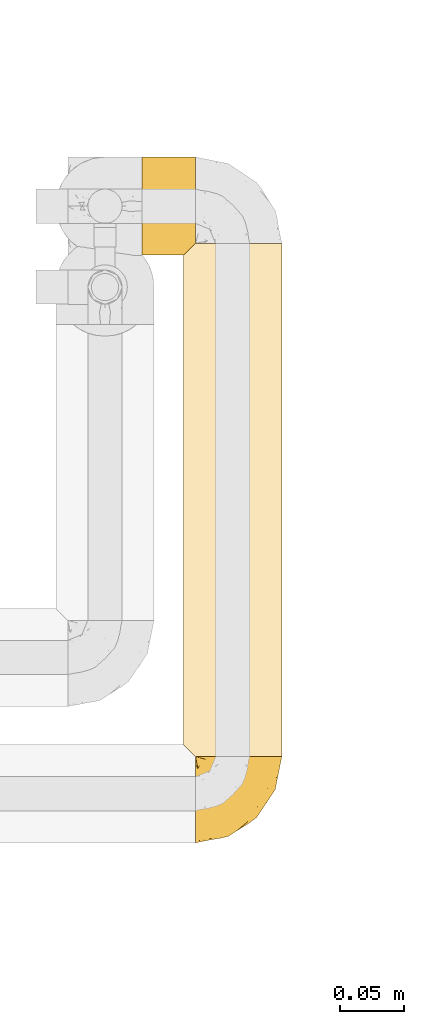
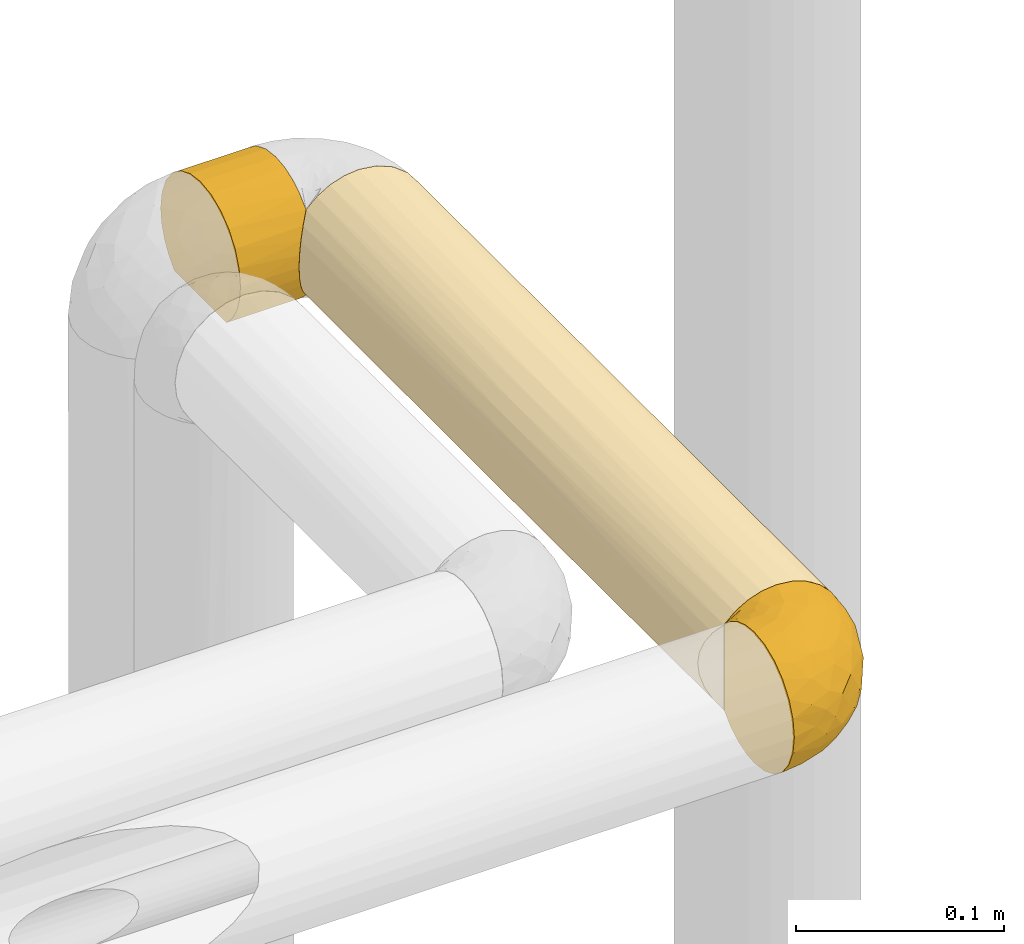
# One storey, part 84 of 827: 3 coverings.
"""IFC2X3 building model written with IfcOpenShell, lengths in millimetres."""

import ifcopenshell
import ifcopenshell.guid

model = None  # the IFC model being written
_history = None  # IfcOwnerHistory: only IFC2X3 demands one
_inside = {}  # id of a spatial element -> (the spatial element, [elements in it])
_under = {}  # id of a project, library or spatial element -> (it, [spatial elements below it])
_declared = {}  # id of a project -> (the project, [libraries it declares])
_typed = {}  # id of a type object -> (the type object, [elements of that type])
_made_of = {}  # id of a material, layer set ... -> (it, [elements and type objects made of it])


def new_model(schema):
    """Start an empty IFC model of exactly this schema.

    Asked for "IFC4X3", IfcOpenShell would pick the latest addendum, in which some entities
    have other attributes; the version numbers below select the first issue.
    IFC2X3 requires an IfcOwnerHistory on every rooted entity: one is made here for all.
    """
    global model, _history
    if schema == "IFC4X3":
        model = ifcopenshell.file(schema_version=(4, 3, 0, 0))
    else:
        model = ifcopenshell.file(schema=schema)
    _inside.clear()
    _under.clear()
    _declared.clear()
    _typed.clear()
    _made_of.clear()
    _history = None
    if model.schema == "IFC2X3":
        org = make("IfcOrganization", Name="unknown")
        user = make(
            "IfcPersonAndOrganization",
            ThePerson=make("IfcPerson", FamilyName="unknown"),
            TheOrganization=org,
        )
        app = make(
            "IfcApplication",
            ApplicationDeveloper=org,
            Version="unknown",
            ApplicationFullName="unknown",
            ApplicationIdentifier="unknown",
        )
        _history = make(
            "IfcOwnerHistory",
            OwningUser=user,
            OwningApplication=app,
            ChangeAction="ADDED",
            CreationDate=0,
        )
    return model


def make(cls, **values):
    """One entity of the class cls with the attributes given. An attribute that is None is left unset."""
    return model.create_entity(
        cls, **{name: value for name, value in values.items() if value is not None}
    )


def entity(cls, *values):
    """Any entity or typed value of the class cls, its attributes in the order of the schema. None: left unset."""
    e = model.create_entity(cls)
    for i, value in enumerate(values):
        if value is not None:
            e[i] = value
    return e


def rooted(cls, **values):
    """An entity with a GlobalId (a new one), such as an element, a storey or a relation."""
    return make(cls, GlobalId=ifcopenshell.guid.new(), OwnerHistory=_history, **values)


def si_unit(unit_type, name, prefix=None):
    """IfcSIUnit, for example si_unit("LENGTHUNIT", "METRE", prefix="MILLI")."""
    return make("IfcSIUnit", UnitType=unit_type, Prefix=prefix, Name=name)


def converted_unit(unit_type, name, factor, base, dimensions=None, offset=None):
    """IfcConversionBasedUnit, such as the inch: factor (a typed value) times the base unit."""
    return make(
        "IfcConversionBasedUnit"
        if offset is None
        else "IfcConversionBasedUnitWithOffset",
        ConversionOffset=offset,
        Dimensions=None
        if dimensions is None
        else entity("IfcDimensionalExponents", *dimensions),
        UnitType=unit_type,
        Name=name,
        ConversionFactor=make(
            "IfcMeasureWithUnit", ValueComponent=factor, UnitComponent=base
        ),
    )


def derived_unit(unit_type, elements):
    """IfcDerivedUnit: a product of units, each with its exponent."""
    return make(
        "IfcDerivedUnit",
        Elements=[
            make("IfcDerivedUnitElement", Unit=unit, Exponent=power)
            for unit, power in elements
        ],
        UnitType=unit_type,
    )


def assignment(units):
    """IfcUnitAssignment: the units of a project."""
    return None if units is None else make("IfcUnitAssignment", Units=units)


def point(xyz):
    """IfcCartesianPoint."""
    return None if xyz is None else make("IfcCartesianPoint", Coordinates=xyz)


def direction(xyz):
    """IfcDirection."""
    return None if xyz is None else make("IfcDirection", DirectionRatios=xyz)


def frame(location, z_axis=None, x_axis=None):
    """IfcAxis2Placement3D, a coordinate frame: its origin and axes. An axis left out is left unset."""
    return make(
        "IfcAxis2Placement3D",
        Location=point(location),
        Axis=direction(z_axis),
        RefDirection=direction(x_axis),
    )


def origin():
    """The frame at (0, 0, 0) with its axes left unset."""
    return frame((0.0, 0.0, 0.0))


def place(relative_to, where):
    """IfcLocalPlacement: puts the frame where relative to a parent placement (None: the world)."""
    return make(
        "IfcLocalPlacement", PlacementRelTo=relative_to, RelativePlacement=where
    )


def context(
    kind, dimensions, precision=None, world=None, true_north=None, identifier=None
):
    """IfcGeometricRepresentationContext, for example the 3D "Model" context."""
    return make(
        "IfcGeometricRepresentationContext",
        ContextIdentifier=identifier,
        ContextType=kind,
        CoordinateSpaceDimension=dimensions,
        Precision=precision,
        WorldCoordinateSystem=world,
        TrueNorth=true_north,
    )


def subcontext(parent, identifier, kind, view, scale=None):
    """IfcGeometricRepresentationSubContext, for example "Body" below "Model"."""
    return make(
        "IfcGeometricRepresentationSubContext",
        ContextIdentifier=identifier,
        ContextType=kind,
        ParentContext=parent,
        TargetScale=scale,
        TargetView=view,
    )


def project(units=None, contexts=None):
    """IfcProject with its units and contexts."""
    return rooted(
        "IfcProject",
        Name="project",
        RepresentationContexts=contexts,
        UnitsInContext=assignment(units),
    )


def spatial(cls, under=None, at=None, **own):
    """A site, building, storey or space (cls), placed at a placement, below another one or the project."""
    s = rooted(cls, ObjectPlacement=at, **own)
    if under is not None:
        _under.setdefault(under.id(), (under, []))[1].append(s)
    return s


def faces_of(points, faces, orient=None, outer=None):
    """IfcFace entities. A face is a list of loops; a loop is a list of indices into points, from 0.

    orient and outer hold one flag for each loop. By default every Orientation is true, the
    first loop of a face is its IfcFaceOuterBound and the others are IfcFaceBound.
    """
    made = []
    for i, loops in enumerate(faces):
        bounds = []
        for j, loop in enumerate(loops):
            is_outer = j == 0 if outer is None else outer[i][j]
            bounds.append(
                make(
                    "IfcFaceOuterBound" if is_outer else "IfcFaceBound",
                    Bound=make("IfcPolyLoop", Polygon=[points[k] for k in loop]),
                    Orientation=True if orient is None else orient[i][j],
                )
            )
        made.append(make("IfcFace", Bounds=bounds))
    return made


def faceted_brep(points, faces, orient=None, outer=None, voids=None):
    """IfcFacetedBrep: a solid bounded by flat faces; with voids (closed shells), ...WithVoids."""
    shared = [point(p) for p in points]
    hull = make("IfcClosedShell", CfsFaces=faces_of(shared, faces, orient, outer))
    if voids is None:
        return make("IfcFacetedBrep", Outer=hull)
    return make(
        "IfcFacetedBrepWithVoids",
        Outer=hull,
        Voids=[
            make(cls, CfsFaces=faces_of(shared, fs, o, b)) for cls, fs, o, b in voids
        ],
    )


def shape(context_of_items, identifier, shape_type, items):
    """IfcShapeRepresentation: the items that make up one representation, for example the "Body"."""
    return make(
        "IfcShapeRepresentation",
        ContextOfItems=context_of_items,
        RepresentationIdentifier=identifier,
        RepresentationType=shape_type,
        Items=items,
    )


def made_of(thing, what):
    """Note that an element or type object is made of a material, layer set ...; save() writes the relation."""
    if what is not None:
        _made_of.setdefault(what.id(), (what, []))[1].append(thing)
    return thing


def element(
    cls,
    number,
    at=None,
    inside=None,
    cuts=None,
    type_object=None,
    material=None,
    context=None,
    identifier="Body",
    shape_type=None,
    held_by="IfcProductDefinitionShape",
    body=None,
    shapes=None,
    **own,
):
    """One element of the class cls, such as IfcWall. Its Tag is "e" and its number.

    at: its placement. inside: the storey or other place that contains it. cuts: it is an
    opening in that element (IfcRelVoidsElement). A single representation is given by context,
    identifier, shape_type and body (its items); several are given by shapes. held_by: the class
    of the entity that holds the representations. save() writes the other relations.
    """
    e = rooted(cls, Tag="e%d" % number, ObjectPlacement=at, **own)
    if body is not None:
        shapes = [shape(context, identifier, shape_type, body)]
    if shapes is not None:
        e.Representation = make(held_by, Representations=shapes)
    if inside is not None:
        _inside.setdefault(inside.id(), (inside, []))[1].append(e)
    if cuts is not None:
        rooted(
            "IfcRelVoidsElement", RelatingBuildingElement=cuts, RelatedOpeningElement=e
        )
    if type_object is not None:
        _typed.setdefault(type_object.id(), (type_object, []))[1].append(e)
    return made_of(e, material)


def aggregate(whole, parts):
    """IfcRelAggregates: a whole, such as a stair, and the parts it consists of."""
    return rooted("IfcRelAggregates", RelatingObject=whole, RelatedObjects=parts)


def save(model, path):
    """Write the relations noted so far, then the file.

    IfcRelAggregates (storeys below a building ...), IfcRelContainedInSpatialStructure (elements
    in a storey), IfcRelDefinesByType, IfcRelAssociatesMaterial and IfcRelDeclares: one each for
    every whole, place, type object, material and project.
    """
    for whole, parts in _under.values():
        aggregate(whole, parts)
    for where, things in _inside.values():
        rooted(
            "IfcRelContainedInSpatialStructure",
            RelatedElements=things,
            RelatingStructure=where,
        )
    for kind, things in _typed.values():
        rooted("IfcRelDefinesByType", RelatedObjects=things, RelatingType=kind)
    for what, things in _made_of.values():
        rooted("IfcRelAssociatesMaterial", RelatedObjects=things, RelatingMaterial=what)
    for by, libraries in _declared.values():
        rooted("IfcRelDeclares", RelatingContext=by, RelatedDefinitions=libraries)
    model.write(path)


model = new_model("IFC2X3")

# Units and contexts
model_context = context("Model", 3, precision=0.01, world=origin(), true_north=direction((6.12303176911189e-17, 1.0)))
body_context = subcontext(model_context, "Body", "Model", "MODEL_VIEW")
ifc_project = project(units=[si_unit("LENGTHUNIT", "METRE", prefix="MILLI"), si_unit("AREAUNIT", "SQUARE_METRE"), si_unit("VOLUMEUNIT", "CUBIC_METRE"), converted_unit("PLANEANGLEUNIT", "DEGREE", entity("IfcRatioMeasure", 0.0174532925199433), si_unit("PLANEANGLEUNIT", "RADIAN"), dimensions=[0, 0, 0, 0, 0, 0, 0]), si_unit("MASSUNIT", "GRAM", prefix="KILO"), derived_unit("MASSDENSITYUNIT", [(si_unit("MASSUNIT", "GRAM", prefix="KILO"), 1), (si_unit("LENGTHUNIT", "METRE"), -3)]), derived_unit("MOMENTOFINERTIAUNIT", [(si_unit("LENGTHUNIT", "METRE"), 4)]), si_unit("TIMEUNIT", "SECOND"), si_unit("FREQUENCYUNIT", "HERTZ"), si_unit("THERMODYNAMICTEMPERATUREUNIT", "DEGREE_CELSIUS"), derived_unit("THERMALTRANSMITTANCEUNIT", [(si_unit("MASSUNIT", "GRAM", prefix="KILO"), 1), (si_unit("THERMODYNAMICTEMPERATUREUNIT", "KELVIN"), -1), (si_unit("TIMEUNIT", "SECOND"), -3)]), derived_unit("VOLUMETRICFLOWRATEUNIT", [(si_unit("LENGTHUNIT", "METRE"), 3), (si_unit("TIMEUNIT", "SECOND"), -1)]), derived_unit("MASSFLOWRATEUNIT", [(si_unit("MASSUNIT", "GRAM", prefix="KILO"), 1), (si_unit("TIMEUNIT", "SECOND"), -1)]), derived_unit("ROTATIONALFREQUENCYUNIT", [(si_unit("TIMEUNIT", "SECOND"), -1)]), si_unit("ELECTRICCURRENTUNIT", "AMPERE"), si_unit("ELECTRICVOLTAGEUNIT", "VOLT"), si_unit("POWERUNIT", "WATT"), si_unit("FORCEUNIT", "NEWTON", prefix="KILO"), si_unit("ILLUMINANCEUNIT", "LUX"), si_unit("LUMINOUSFLUXUNIT", "LUMEN"), si_unit("LUMINOUSINTENSITYUNIT", "CANDELA"), derived_unit("USERDEFINED", [(si_unit("MASSUNIT", "GRAM", prefix="KILO"), -1), (si_unit("LENGTHUNIT", "METRE"), -2), (si_unit("TIMEUNIT", "SECOND"), 3), (si_unit("LUMINOUSFLUXUNIT", "LUMEN"), 1)]), derived_unit("LINEARVELOCITYUNIT", [(si_unit("LENGTHUNIT", "METRE"), 1), (si_unit("TIMEUNIT", "SECOND"), -1)]), si_unit("PRESSUREUNIT", "PASCAL"), derived_unit("USERDEFINED", [(si_unit("LENGTHUNIT", "METRE"), -2), (si_unit("MASSUNIT", "GRAM", prefix="KILO"), 1), (si_unit("TIMEUNIT", "SECOND"), -2)]), derived_unit("LINEARFORCEUNIT", [(si_unit("MASSUNIT", "GRAM", prefix="KILO"), 1), (si_unit("LENGTHUNIT", "METRE"), 1), (si_unit("TIMEUNIT", "SECOND"), -2), (si_unit("LENGTHUNIT", "METRE"), -1)]), derived_unit("PLANARFORCEUNIT", [(si_unit("MASSUNIT", "GRAM", prefix="KILO"), 1), (si_unit("LENGTHUNIT", "METRE"), 1), (si_unit("TIMEUNIT", "SECOND"), -2), (si_unit("LENGTHUNIT", "METRE"), -2)])], contexts=[model_context])

# Site, building, storey
site_placement = place(None, origin())
site = spatial("IfcSite", under=ifc_project, at=site_placement, CompositionType="ELEMENT")
building_placement = place(site_placement, origin())
building = spatial("IfcBuilding", under=site, at=building_placement, CompositionType="ELEMENT")
storey_placement = place(building_placement, frame((0.0, 0.0, 28200.0)))
storey = spatial("IfcBuildingStorey", under=building, at=storey_placement, Name="08", CompositionType="ELEMENT", Elevation=28200.0)

# Coverings
covering_1_placement = place(storey_placement, frame((18946.14, 11787.02, 1860.0)))
element("IfcCovering", 1, at=covering_1_placement, inside=storey, Name=":ADSK_", ObjectType=":ADSK_", PredefinedType="INSULATION", context=body_context, shape_type="Brep", body=[
    faceted_brep([(23.98, 1.6, 5.09), (31.79, 1.6, 2.48), (40.0, 1.6, 1.6), (49.93, 1.6, 2.9), (59.2, 1.6, 6.74), (67.15, 1.6, 12.84), (73.25, 1.6, 20.8), (77.09, 1.6, 30.06), (78.4, 1.6, 40.0), (77.09, 1.6, 49.93), (73.25, 1.6, 59.2), (67.15, 1.6, 67.15), (59.2, 1.6, 73.25), (49.93, 1.6, 77.09), (40.0, 1.6, 78.4), (31.79, 1.6, 77.51), (23.98, 1.6, 74.9), (16.91, 1.6, 70.68), (10.9, 1.6, 65.05), (10.9, 1.6, 14.94), (16.91, 1.6, 9.31), (40.0, 403.4, 1.6), (31.79, 403.4, 2.48), (23.98, 403.4, 5.09), (16.91, 403.4, 9.31), (10.9, 403.4, 14.94), (10.9, 403.4, 65.05), (16.91, 403.4, 70.68), (23.98, 403.4, 74.9), (31.79, 403.4, 77.51), (40.0, 403.4, 78.4), (49.93, 403.4, 77.09), (59.2, 403.4, 73.25), (67.15, 403.4, 67.15), (73.25, 403.4, 59.2), (77.09, 403.4, 49.93), (78.4, 403.4, 40.0), (77.09, 403.4, 30.06), (73.25, 403.4, 20.8), (67.15, 403.4, 12.84), (59.2, 403.4, 6.74), (49.93, 403.4, 2.9), (2.2, 394.7, 33.21), (2.97, 202.5, 29.82), (1.6, 394.1, 40.0), (14.06, 200.33, 11.67), (8.87, 202.5, 17.51), (5.37, 224.77, 23.4), (6.92, 399.42, 20.48), (2.2, 10.29, 33.21), (4.0, 8.5, 26.63), (20.33, 202.5, 7.01), (4.0, 396.5, 26.63), (1.6, 10.9, 40.0), (27.82, 202.5, 3.58), (6.92, 5.57, 20.48), (40.0, 187.02, 1.6), (40.0, 217.97, 1.6), (54.69, 202.5, 4.52), (47.67, 202.5, 2.37), (77.62, 202.5, 32.32), (63.37, 202.5, 9.53), (70.46, 202.5, 16.62), (78.4, 217.97, 40.0), (78.4, 187.02, 40.0), (75.47, 202.5, 25.3), (75.47, 202.5, 54.69), (77.62, 202.5, 47.67), (47.67, 202.5, 77.62), (70.46, 202.5, 63.37), (63.37, 202.5, 70.46), (40.0, 217.97, 78.4), (40.0, 187.02, 78.4), (54.69, 202.5, 75.47), (27.82, 202.5, 76.41), (20.33, 202.5, 72.98), (14.06, 204.66, 68.32), (8.87, 202.5, 62.48), (4.0, 396.5, 53.36), (2.97, 202.5, 50.17), (5.37, 180.22, 56.59), (2.2, 394.7, 46.78), (6.92, 399.42, 59.51), (4.0, 8.5, 53.36), (6.92, 5.57, 59.51), (2.2, 10.29, 46.78)], [[[0, 1, 2, 3, 4, 5, 6, 7, 8, 9, 10, 11, 12, 13, 14, 15, 16, 17, 18, 19, 20]], [[21, 22, 23, 24, 25, 26, 27, 28, 29, 30, 31, 32, 33, 34, 35, 36, 37, 38, 39, 40, 41]], [[42, 43, 44]], [[25, 24, 45]], [[46, 47, 48]], [[49, 43, 50]], [[20, 51, 0]], [[42, 52, 43]], [[48, 25, 46]], [[44, 43, 53]], [[54, 51, 23]], [[50, 47, 55]], [[50, 43, 47]], [[52, 48, 47]], [[43, 49, 53]], [[0, 54, 1]], [[46, 19, 55]], [[54, 22, 56]], [[51, 24, 23]], [[54, 23, 22]], [[56, 2, 1]], [[22, 21, 57, 56]], [[19, 46, 45]], [[45, 24, 51]], [[45, 51, 20]], [[0, 51, 54]], [[55, 47, 46]], [[45, 46, 25]], [[19, 45, 20]], [[52, 47, 43]], [[56, 1, 54]], [[58, 59, 41]], [[36, 60, 37]], [[21, 59, 2, 56, 57]], [[58, 41, 40]], [[59, 21, 41]], [[3, 58, 4]], [[58, 3, 59]], [[61, 5, 4]], [[61, 58, 40]], [[62, 61, 39]], [[8, 60, 36, 63, 64]], [[65, 38, 37]], [[60, 7, 65]], [[8, 7, 60]], [[62, 6, 5]], [[65, 62, 38]], [[65, 37, 60]], [[65, 6, 62]], [[61, 62, 5]], [[39, 61, 40]], [[6, 65, 7]], [[38, 62, 39]], [[2, 59, 3]], [[58, 61, 4]], [[66, 67, 35]], [[30, 68, 31]], [[36, 67, 8, 64, 63]], [[66, 35, 34]], [[67, 36, 35]], [[9, 66, 10]], [[66, 9, 67]], [[69, 11, 10]], [[69, 66, 34]], [[70, 69, 33]], [[14, 68, 30, 71, 72]], [[73, 32, 31]], [[68, 13, 73]], [[14, 13, 68]], [[70, 12, 11]], [[73, 70, 32]], [[73, 31, 68]], [[73, 12, 70]], [[69, 70, 11]], [[33, 69, 34]], [[12, 73, 13]], [[32, 70, 33]], [[8, 67, 9]], [[66, 69, 10]], [[74, 71, 29]], [[74, 29, 28]], [[75, 28, 27]], [[15, 74, 16]], [[29, 71, 30]], [[15, 14, 72, 71]], [[71, 74, 15]], [[16, 74, 75]], [[26, 76, 27]], [[16, 75, 17]], [[75, 76, 17]], [[76, 75, 27]], [[77, 76, 26]], [[78, 79, 80]], [[81, 79, 78]], [[79, 81, 44]], [[18, 17, 76]], [[75, 74, 28]], [[78, 80, 82]], [[83, 84, 80]], [[80, 84, 77]], [[53, 85, 79]], [[85, 83, 79]], [[82, 80, 77]], [[84, 18, 77]], [[79, 44, 53]], [[83, 80, 79]], [[82, 77, 26]], [[76, 77, 18]], [[53, 49, 50, 55, 19, 18, 84, 83, 85]], [[81, 78, 82, 26, 25, 48, 52, 42, 44]]]),
])
covering_2_placement = place(storey_placement, frame((18955.44, 11719.47, 1859.95)))
element("IfcCovering", 2, at=covering_2_placement, inside=storey, Name=":ADSK_", ObjectType=":ADSK_", PredefinedType="INSULATION", context=body_context, shape_type="Brep", body=[
    faceted_brep([(47.38, 69.15, 74.68), (54.67, 69.15, 70.1), (60.76, 69.15, 64.01), (65.34, 69.15, 56.72), (68.18, 69.15, 48.6), (69.15, 69.15, 40.05), (68.18, 69.15, 31.49), (65.33, 69.15, 23.36), (60.75, 69.15, 16.07), (54.66, 69.15, 9.98), (47.37, 69.15, 5.4), (39.25, 69.15, 2.56), (30.7, 69.15, 1.6), (22.59, 69.15, 2.46), (14.86, 69.15, 5.01), (7.84, 69.15, 9.13), (1.85, 69.15, 14.62), (1.85, 69.15, 16.82), (1.85, 69.15, 18.56), (1.85, 69.15, 20.52), (1.85, 69.15, 22.49), (1.85, 69.15, 24.46), (1.85, 69.15, 26.42), (1.85, 69.15, 28.39), (1.85, 69.15, 30.36), (1.85, 69.15, 32.55), (1.85, 69.15, 34.75), (1.85, 69.15, 36.94), (1.85, 69.15, 39.13), (1.85, 69.15, 41.33), (1.85, 69.15, 43.52), (1.85, 69.15, 45.72), (1.85, 69.15, 47.91), (1.85, 69.15, 50.11), (1.85, 69.15, 52.3), (1.85, 69.15, 54.49), (1.85, 69.15, 56.69), (1.85, 69.15, 58.88), (1.85, 69.15, 61.08), (1.85, 69.15, 63.27), (1.85, 69.15, 65.47), (7.85, 69.15, 70.97), (14.88, 69.15, 75.09), (22.61, 69.15, 77.64), (30.7, 69.15, 78.5), (39.26, 69.15, 77.53), (1.6, 68.89, 14.62), (1.6, 62.89, 9.12), (1.6, 55.87, 5.0), (1.6, 48.14, 2.46), (1.6, 40.05, 1.6), (1.6, 30.09, 2.91), (1.6, 20.82, 6.75), (1.6, 12.86, 12.86), (1.6, 6.75, 20.82), (1.6, 2.91, 30.09), (1.6, 1.6, 40.05), (1.6, 2.91, 50.0), (1.6, 6.75, 59.27), (1.6, 12.86, 67.23), (1.6, 20.82, 73.34), (1.6, 30.09, 77.19), (1.6, 40.05, 78.5), (1.6, 48.14, 77.63), (1.6, 55.87, 75.09), (1.6, 62.89, 70.97), (1.6, 68.89, 65.47), (1.6, 68.89, 63.27), (1.6, 68.89, 62.29), (1.6, 68.89, 60.7), (1.6, 68.89, 59.11), (1.6, 68.89, 57.52), (1.6, 68.89, 55.93), (1.6, 68.89, 54.34), (1.6, 68.89, 52.76), (1.6, 68.89, 51.17), (1.6, 68.89, 49.58), (1.6, 68.89, 47.99), (1.6, 68.89, 46.4), (1.6, 68.89, 44.81), (1.6, 68.89, 43.22), (1.6, 68.89, 41.63), (1.6, 68.89, 40.05), (1.6, 68.89, 38.46), (1.6, 68.89, 36.87), (1.6, 68.89, 35.28), (1.6, 68.89, 33.69), (1.6, 68.89, 32.1), (1.6, 68.89, 30.51), (1.6, 68.89, 28.92), (1.6, 68.89, 27.33), (1.6, 68.89, 25.37), (1.6, 68.89, 23.4), (1.6, 68.89, 21.21), (1.6, 68.89, 19.01), (1.6, 68.89, 16.82), (1.78, 68.97, 42.32), (1.77, 68.96, 44.02), (1.78, 68.97, 47.13), (1.77, 68.97, 48.74), (1.79, 68.98, 23.57), (1.78, 68.97, 25.13), (1.76, 68.96, 61.34), (1.77, 68.96, 22.02), (1.77, 68.96, 29.72), (1.76, 68.96, 56.73), (1.77, 68.96, 55.14), (1.77, 68.96, 37.66), (1.8, 69.0, 64.12), (1.76, 68.96, 28.13), (1.77, 68.96, 26.62), (1.78, 68.97, 31.46), (1.77, 68.96, 16.16), (1.77, 68.96, 39.16), (1.76, 68.96, 50.37), (1.77, 68.97, 17.69), (1.78, 68.97, 19.17), (1.77, 68.97, 62.78), (1.77, 68.96, 58.35), (1.77, 68.96, 45.53), (1.78, 68.97, 59.91), (1.77, 68.97, 65.47), (1.8, 69.02, 65.47), (1.82, 69.08, 65.47), (1.77, 68.97, 14.62), (1.72, 68.94, 14.62), (1.66, 68.92, 14.62), (1.76, 68.96, 20.59), (1.77, 68.96, 32.99), (1.76, 68.95, 34.48), (1.77, 68.96, 51.91), (1.66, 68.92, 65.47), (1.72, 68.94, 65.47), (1.78, 68.98, 53.48), (1.82, 69.08, 14.62), (1.8, 69.02, 14.62), (1.77, 68.96, 40.77), (1.78, 68.97, 35.97), (3.72, 61.33, 7.84), (7.41, 53.1, 3.53), (6.13, 63.33, 8.32), (21.47, 49.27, 1.6), (19.34, 55.53, 2.19), (26.8, 54.6, 1.6), (8.87, 41.99, 1.6), (9.2, 57.07, 4.57), (12.79, 57.95, 3.96), (14.62, 51.56, 2.28), (7.34, 41.58, 1.6), (5.33, 61.7, 7.69), (17.64, 63.33, 3.53), (7.7, 65.0, 8.32), (9.41, 67.02, 7.84), (28.75, 61.87, 1.6), (16.15, 43.94, 1.6), (14.14, 61.21, 4.34), (29.16, 63.4, 1.6), (57.02, 33.11, 29.63), (64.92, 52.82, 27.34), (64.0, 43.3, 40.05), (11.92, 33.73, 2.39), (19.16, 36.52, 2.43), (28.65, 24.87, 9.07), (24.62, 14.17, 16.64), (15.19, 18.43, 9.54), (18.36, 28.67, 4.52), (9.2, 26.0, 4.52), (46.98, 49.25, 7.49), (50.24, 59.72, 7.49), (56.1, 55.1, 12.85), (28.97, 44.72, 2.35), (54.46, 34.15, 22.66), (21.34, 5.25, 32.9), (18.4, 6.75, 25.33), (66.44, 55.54, 40.05), (12.07, 10.47, 16.64), (45.49, 25.49, 19.99), (50.57, 35.53, 16.37), (36.04, 48.22, 3.26), (42.07, 58.71, 3.75), (62.12, 57.42, 19.58), (37.37, 34.84, 7.5), (29.39, 36.87, 4.04), (53.59, 45.01, 13.94), (58.06, 44.4, 19.58), (49.27, 23.96, 28.21), (29.63, 11.2, 24.75), (33.21, 10.56, 31.42), (40.1, 16.81, 26.2), (44.08, 17.38, 33.36), (49.36, 21.38, 40.05), (56.68, 32.34, 40.05), (15.2, 4.3, 40.05), (35.57, 20.65, 16.14), (41.7, 29.66, 12.85), (46.4, 39.6, 10.47), (41.41, 42.55, 6.49), (27.45, 6.74, 40.05), (38.4, 14.06, 40.05), (12.99, 26.84, 75.57), (21.33, 5.28, 47.37), (42.89, 18.52, 52.91), (57.04, 33.13, 50.46), (56.11, 55.1, 67.23), (62.13, 57.43, 60.5), (21.89, 20.72, 70.55), (16.62, 11.46, 63.45), (32.9, 17.69, 62.61), (46.99, 49.26, 72.6), (50.25, 59.73, 72.6), (42.08, 58.71, 76.34), (49.91, 29.72, 59.34), (15.6, 35.35, 77.76), (16.15, 43.94, 78.5), (8.87, 41.99, 78.5), (29.16, 63.4, 78.5), (13.16, 4.93, 53.16), (10.83, 17.46, 70.55), (33.8, 10.94, 48.88), (25.02, 8.92, 54.76), (64.92, 52.83, 52.74), (32.83, 29.34, 71.93), (20.56, 30.26, 75.79), (58.07, 44.4, 60.5), (21.46, 39.06, 77.86), (28.1, 43.06, 77.64), (26.8, 54.6, 78.5), (21.47, 49.27, 78.5), (51.29, 42.69, 67.23), (36.04, 48.2, 76.82), (28.75, 61.87, 78.5), (8.45, 33.44, 77.8), (41.73, 29.67, 67.23), (39.27, 38.5, 73.2), (33.56, 23.35, 67.66), (27.29, 34.97, 75.99), (7.41, 53.1, 76.57), (3.51, 59.68, 73.21), (4.68, 62.19, 71.93), (5.52, 64.11, 71.07), (8.75, 57.97, 75.09), (12.79, 57.95, 76.13), (17.65, 63.33, 76.57), (13.9, 51.77, 77.69), (9.42, 67.02, 72.26), (7.68, 64.98, 71.77), (19.33, 55.53, 77.9), (14.13, 61.22, 75.75)], [[[0, 1, 2, 3, 4, 5, 6, 7, 8, 9, 10, 11, 12, 13, 14, 15, 16, 17, 18, 19, 20, 21, 22, 23, 24, 25, 26, 27, 28, 29, 30, 31, 32, 33, 34, 35, 36, 37, 38, 39, 40, 41, 42, 43, 44, 45]], [[46, 47, 48, 49, 50, 51, 52, 53, 54, 55, 56, 57, 58, 59, 60, 61, 62, 63, 64, 65, 66, 67, 68, 69, 70, 71, 72, 73, 74, 75, 76, 77, 78, 79, 80, 81, 82, 83, 84, 85, 86, 87, 88, 89, 90, 91, 92, 93, 94, 95]], [[96, 97, 30]], [[98, 77, 99]], [[100, 101, 21]], [[69, 68, 102]], [[20, 19, 103]], [[24, 23, 104]], [[20, 103, 100]], [[72, 105, 106]], [[84, 83, 107]], [[89, 88, 104]], [[108, 67, 66]], [[109, 110, 90]], [[111, 25, 24]], [[112, 17, 16]], [[82, 113, 83]], [[109, 23, 22]], [[114, 76, 75]], [[105, 36, 106]], [[104, 111, 24]], [[18, 115, 116]], [[97, 96, 80]], [[67, 108, 117]], [[105, 71, 118]], [[31, 97, 119]], [[102, 120, 69]], [[108, 121, 122, 123, 40]], [[112, 95, 115]], [[17, 115, 18]], [[94, 116, 115]], [[117, 68, 67]], [[38, 117, 39]], [[112, 124, 125, 126, 46]], [[17, 112, 115]], [[70, 120, 118]], [[39, 117, 108]], [[120, 38, 37]], [[120, 37, 118]], [[120, 70, 69]], [[116, 94, 127]], [[128, 86, 129]], [[117, 38, 102]], [[74, 130, 75]], [[99, 33, 32]], [[115, 95, 94]], [[39, 108, 40]], [[108, 66, 131, 132, 121]], [[105, 72, 71]], [[118, 37, 36]], [[71, 70, 118]], [[35, 106, 36]], [[36, 105, 118]], [[35, 133, 106]], [[74, 73, 133]], [[106, 133, 73]], [[99, 114, 33]], [[133, 35, 34]], [[73, 72, 106]], [[95, 112, 46]], [[112, 16, 134, 135, 124]], [[130, 114, 75]], [[99, 76, 114]], [[114, 130, 33]], [[34, 33, 130]], [[78, 77, 98]], [[98, 119, 78]], [[130, 133, 34]], [[133, 130, 74]], [[79, 97, 80]], [[98, 99, 32]], [[98, 32, 31]], [[77, 76, 99]], [[97, 79, 119]], [[136, 96, 29]], [[30, 97, 31]], [[136, 29, 28]], [[81, 80, 96]], [[29, 96, 30]], [[31, 119, 98]], [[119, 79, 78]], [[96, 136, 81]], [[82, 81, 136]], [[113, 107, 83]], [[84, 107, 137]], [[107, 27, 137]], [[113, 28, 107]], [[27, 107, 28]], [[85, 84, 137]], [[137, 27, 26]], [[113, 136, 28]], [[136, 113, 82]], [[109, 89, 104]], [[86, 85, 129]], [[89, 109, 90]], [[111, 87, 128]], [[26, 129, 137]], [[88, 111, 104]], [[25, 111, 128]], [[22, 110, 109]], [[23, 109, 104]], [[110, 91, 90]], [[100, 92, 101]], [[110, 22, 101]], [[91, 110, 101]], [[116, 19, 18]], [[111, 88, 87]], [[127, 103, 19]], [[25, 128, 26]], [[86, 128, 87]], [[128, 129, 26]], [[137, 129, 85]], [[120, 102, 38]], [[117, 102, 68]], [[91, 101, 92]], [[21, 101, 22]], [[93, 92, 103]], [[100, 21, 20]], [[100, 103, 92]], [[127, 93, 103]], [[93, 127, 94]], [[116, 127, 19]], [[126, 138, 47]], [[48, 138, 139]], [[140, 125, 124]], [[141, 142, 143]], [[144, 49, 139]], [[145, 140, 146]], [[48, 139, 49]], [[139, 145, 147]], [[49, 144, 148, 50]], [[126, 125, 149]], [[14, 13, 150]], [[151, 146, 140]], [[149, 140, 145]], [[152, 151, 135]], [[152, 14, 150]], [[16, 15, 134]], [[13, 153, 150]], [[124, 151, 140]], [[141, 147, 142]], [[14, 152, 15]], [[15, 152, 134]], [[47, 46, 126]], [[139, 154, 144]], [[138, 48, 47]], [[125, 140, 149]], [[135, 134, 152]], [[146, 155, 142]], [[145, 146, 147]], [[149, 139, 138]], [[147, 141, 154]], [[147, 146, 142]], [[139, 147, 154]], [[139, 149, 145]], [[149, 138, 126]], [[155, 146, 151]], [[150, 143, 142]], [[152, 155, 151]], [[150, 142, 155]], [[13, 12, 156, 153]], [[153, 143, 150]], [[152, 150, 155]], [[151, 124, 135]], [[157, 158, 159]], [[160, 154, 161]], [[162, 163, 164]], [[165, 166, 160]], [[167, 168, 169]], [[141, 170, 161]], [[156, 12, 11]], [[158, 157, 171]], [[172, 55, 173]], [[158, 6, 174]], [[175, 54, 53]], [[52, 166, 164]], [[52, 164, 53]], [[54, 175, 173]], [[166, 52, 51]], [[176, 177, 171]], [[178, 143, 179]], [[156, 11, 179]], [[8, 7, 180]], [[169, 9, 8]], [[179, 143, 153, 156]], [[179, 11, 10]], [[168, 179, 10]], [[181, 162, 182]], [[179, 167, 178]], [[183, 184, 177]], [[183, 169, 184]], [[176, 171, 185]], [[172, 186, 187]], [[158, 7, 6]], [[159, 158, 174]], [[184, 180, 158]], [[54, 173, 55]], [[180, 169, 8]], [[188, 189, 187]], [[9, 168, 10]], [[186, 188, 187]], [[190, 157, 159, 191]], [[55, 172, 192]], [[176, 193, 194]], [[161, 170, 182]], [[162, 164, 165]], [[175, 164, 163]], [[51, 50, 148]], [[167, 195, 196]], [[178, 182, 170]], [[6, 5, 174]], [[158, 180, 7]], [[169, 180, 184]], [[169, 168, 9]], [[179, 168, 167]], [[182, 162, 165]], [[162, 194, 193]], [[161, 165, 160]], [[195, 181, 196]], [[192, 172, 197]], [[192, 56, 55]], [[189, 190, 198]], [[198, 197, 187]], [[172, 187, 197]], [[185, 189, 188]], [[198, 187, 189]], [[186, 172, 173]], [[173, 163, 186]], [[193, 186, 163]], [[176, 185, 188]], [[185, 157, 190]], [[188, 186, 193]], [[177, 176, 194]], [[188, 193, 176]], [[162, 193, 163]], [[195, 177, 194]], [[171, 177, 184]], [[181, 195, 194]], [[183, 167, 169]], [[162, 181, 194]], [[196, 182, 178]], [[158, 171, 184]], [[171, 157, 185]], [[177, 195, 183]], [[167, 183, 195]], [[182, 196, 181]], [[178, 170, 143]], [[178, 167, 196]], [[164, 175, 53]], [[173, 175, 163]], [[160, 51, 148]], [[164, 166, 165]], [[51, 160, 166]], [[160, 148, 144, 154]], [[141, 161, 154]], [[182, 165, 161]], [[190, 189, 185]], [[143, 170, 141]], [[60, 199, 61]], [[197, 200, 192]], [[201, 190, 202]], [[200, 57, 192]], [[203, 204, 2]], [[205, 206, 207]], [[208, 209, 210]], [[211, 207, 201]], [[212, 213, 214]], [[45, 215, 210]], [[216, 206, 58]], [[45, 44, 215]], [[59, 217, 60]], [[60, 217, 199]], [[0, 45, 210]], [[218, 201, 219]], [[202, 159, 220]], [[205, 221, 222]], [[223, 204, 203]], [[1, 203, 2]], [[57, 200, 216]], [[220, 3, 204]], [[220, 174, 4]], [[1, 0, 209]], [[212, 224, 213]], [[225, 226, 227]], [[228, 223, 203]], [[208, 210, 229]], [[210, 226, 229]], [[3, 220, 4]], [[58, 206, 59]], [[209, 203, 1]], [[202, 220, 223]], [[228, 203, 208]], [[202, 211, 201]], [[3, 2, 204]], [[202, 190, 191, 159]], [[210, 215, 230, 226]], [[199, 212, 231]], [[232, 233, 221]], [[233, 208, 229]], [[207, 206, 219]], [[217, 206, 205]], [[227, 224, 225]], [[233, 232, 228]], [[201, 207, 219]], [[234, 232, 221]], [[218, 219, 200]], [[202, 223, 211]], [[174, 220, 159]], [[174, 5, 4]], [[61, 231, 62]], [[220, 204, 223]], [[210, 209, 0]], [[203, 209, 208]], [[225, 233, 229]], [[224, 227, 213]], [[221, 233, 235]], [[57, 56, 192]], [[198, 218, 197]], [[200, 219, 216]], [[201, 198, 190]], [[197, 218, 200]], [[198, 201, 218]], [[206, 216, 219]], [[58, 57, 216]], [[231, 212, 214]], [[222, 212, 199]], [[228, 211, 223]], [[207, 211, 232]], [[62, 231, 214]], [[199, 231, 61]], [[233, 228, 208]], [[211, 228, 232]], [[222, 221, 235]], [[234, 205, 207]], [[206, 217, 59]], [[199, 217, 205]], [[205, 222, 199]], [[224, 222, 235]], [[222, 224, 212]], [[224, 235, 225]], [[233, 225, 235]], [[226, 225, 229]], [[205, 234, 221]], [[207, 232, 234]], [[63, 214, 236]], [[214, 213, 236]], [[214, 63, 62]], [[237, 236, 238]], [[238, 132, 131]], [[236, 237, 64]], [[239, 240, 241]], [[63, 236, 64]], [[131, 66, 65]], [[237, 131, 65]], [[242, 230, 43]], [[237, 65, 64]], [[239, 121, 132]], [[42, 242, 43]], [[241, 240, 243]], [[41, 123, 244]], [[43, 230, 215, 44]], [[244, 122, 245]], [[227, 246, 243]], [[241, 247, 245]], [[121, 239, 245]], [[41, 40, 123]], [[132, 238, 239]], [[244, 42, 41]], [[131, 237, 238]], [[240, 239, 238]], [[245, 239, 241]], [[247, 241, 246]], [[247, 244, 245]], [[238, 236, 240]], [[243, 236, 213]], [[236, 243, 240]], [[227, 226, 246]], [[243, 213, 227]], [[242, 246, 226]], [[243, 246, 241]], [[246, 242, 247]], [[244, 247, 242]], [[242, 226, 230]], [[42, 244, 242]], [[122, 244, 123]], [[122, 121, 245]]]),
])
covering_3_placement = place(storey_placement, frame((18913.64, 12179.52, 1860.0)))
element("IfcCovering", 3, at=covering_3_placement, inside=storey, Name=":ADSK_", ObjectType=":ADSK_", PredefinedType="INSULATION", context=body_context, shape_type="Brep", body=[
    faceted_brep([(1.6, 2.48, 31.79), (1.6, 1.6, 40.0), (1.6, 2.9, 49.93), (1.6, 6.74, 59.2), (1.6, 12.84, 67.15), (1.6, 20.8, 73.25), (1.6, 30.06, 77.09), (1.6, 40.0, 78.4), (1.6, 49.93, 77.09), (1.6, 59.2, 73.25), (1.6, 67.15, 67.15), (1.6, 73.25, 59.2), (1.6, 77.09, 49.93), (1.6, 78.4, 40.0), (1.6, 77.51, 31.79), (1.6, 74.9, 23.98), (1.6, 70.68, 16.91), (1.6, 65.05, 10.9), (1.6, 14.94, 10.9), (1.6, 9.31, 16.91), (1.6, 5.09, 23.98), (43.4, 10.9, 14.94), (43.4, 16.91, 9.31), (43.4, 23.98, 5.09), (43.4, 31.79, 2.48), (43.4, 40.0, 1.6), (43.4, 49.93, 2.9), (43.4, 59.2, 6.74), (43.4, 67.15, 12.84), (43.4, 73.25, 20.8), (43.4, 77.09, 30.06), (43.4, 78.4, 40.0), (43.4, 77.09, 49.93), (43.4, 73.25, 59.2), (43.4, 67.15, 67.15), (43.4, 59.2, 73.25), (43.4, 49.93, 77.09), (43.4, 40.0, 78.4), (43.4, 31.79, 77.51), (43.4, 23.98, 74.9), (43.4, 16.91, 70.68), (43.4, 10.9, 65.05), (8.5, 53.36, 4.0), (10.29, 46.78, 2.2), (10.9, 40.0, 1.6), (5.57, 59.51, 6.92), (10.29, 33.21, 2.2), (5.57, 20.48, 6.92), (8.5, 26.63, 4.0), (39.42, 6.92, 20.48), (36.5, 4.0, 26.63), (34.7, 2.2, 33.21), (34.1, 1.6, 40.0), (34.7, 2.2, 46.78), (36.5, 4.0, 53.36), (39.42, 6.92, 59.51)], [[[0, 1, 2, 3, 4, 5, 6, 7, 8, 9, 10, 11, 12, 13, 14, 15, 16, 17, 18, 19, 20]], [[21, 22, 23, 24, 25, 26, 27, 28, 29, 30, 31, 32, 33, 34, 35, 36, 37, 38, 39, 40, 41]], [[14, 31, 30]], [[29, 28, 16]], [[15, 30, 29]], [[13, 31, 14]], [[15, 14, 30]], [[16, 15, 29]], [[28, 17, 16]], [[42, 27, 26]], [[26, 25, 43]], [[44, 43, 25]], [[17, 28, 45]], [[43, 42, 26]], [[45, 27, 42]], [[45, 28, 27]], [[46, 25, 24]], [[23, 22, 47]], [[48, 24, 23]], [[46, 44, 25]], [[47, 48, 23]], [[18, 47, 22]], [[46, 24, 48]], [[22, 21, 18]], [[21, 49, 19]], [[50, 51, 0]], [[49, 50, 20]], [[19, 49, 20]], [[51, 1, 0]], [[0, 20, 50]], [[1, 51, 52]], [[21, 19, 18]], [[53, 54, 2]], [[3, 55, 4]], [[54, 55, 3]], [[52, 53, 1]], [[1, 53, 2]], [[54, 3, 2]], [[55, 41, 4]], [[5, 40, 39]], [[6, 39, 38]], [[7, 38, 37]], [[4, 40, 5]], [[5, 39, 6]], [[38, 7, 6]], [[40, 4, 41]], [[36, 35, 9, 8]], [[37, 36, 8, 7]], [[35, 34, 10, 9]], [[12, 11, 33, 32]], [[13, 12, 32, 31]], [[34, 33, 11, 10]], [[17, 45, 42, 43, 44, 46, 48, 47, 18]], [[51, 50, 49, 21, 41, 55, 54, 53, 52]]]),
])

save(model, "model.ifc")
